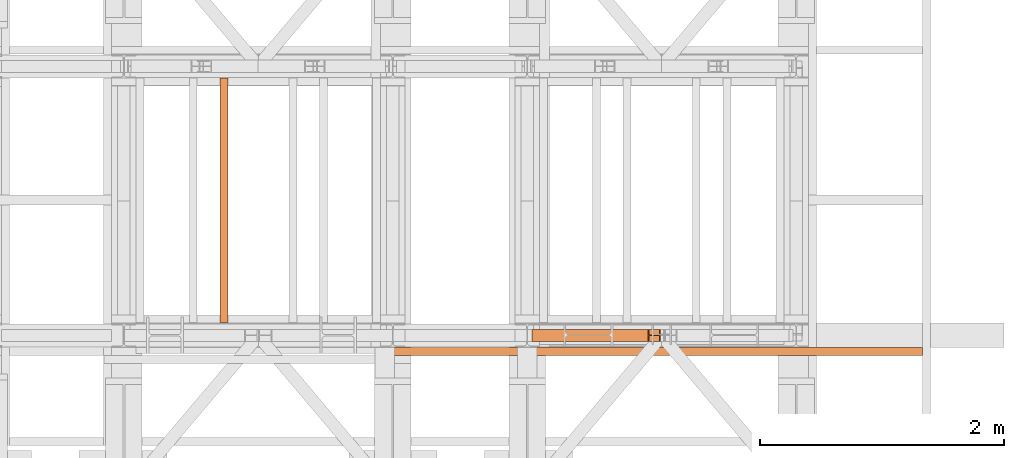
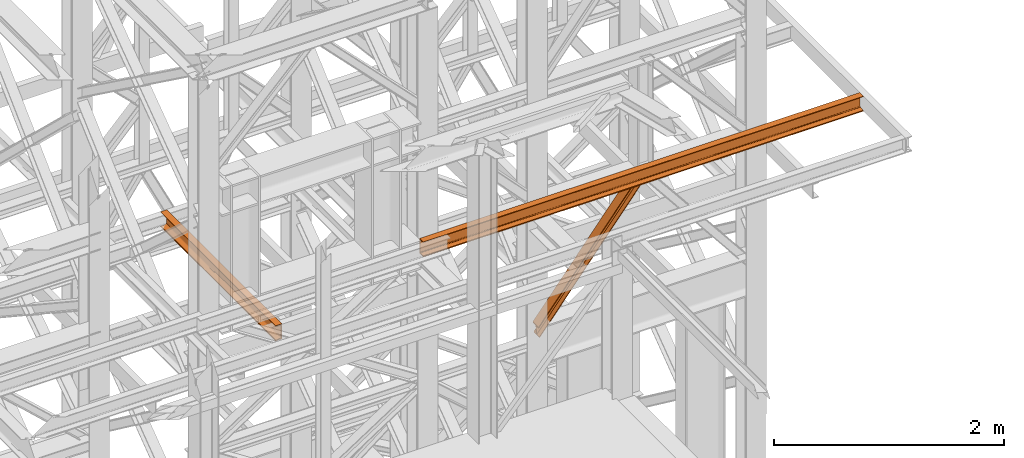
# One storey, part 155 of 208: 3 proxies.
"""IFC2X3 building model written with IfcOpenShell, lengths in millimetres."""

from ifc_helpers import new_model, entity, si_unit, converted_unit, frame, origin, origin_with_axes, place, context, subcontext, project, spatial, faceted_brep, element, save


model = new_model("IFC2X3")

# Units and contexts
model_context = context("Model", 3, precision=1e-05, world=origin())
plan_context = context("Plan", 3, precision=1e-05, world=origin())
body_context = subcontext(model_context, "Body", "Model", "MODEL_VIEW")
ifc_project = project(units=[si_unit("LENGTHUNIT", "METRE", prefix="MILLI"), converted_unit("PLANEANGLEUNIT", "DEGREE", entity("IfcPlaneAngleMeasure", 0.0174532925199433), si_unit("PLANEANGLEUNIT", "RADIAN"), dimensions=[0, 0, 0, 0, 0, 0, 0]), si_unit("AREAUNIT", "SQUARE_METRE"), si_unit("VOLUMEUNIT", "CUBIC_METRE")], contexts=[model_context, plan_context])

# Building, storey
building_placement = place(None, origin())
building = spatial("IfcBuilding", under=ifc_project, at=building_placement, CompositionType="COMPLEX")
storey_placement = place(building_placement, origin_with_axes())
storey = spatial("IfcBuildingStorey", under=building, at=storey_placement, Name="Geschoss", CompositionType="ELEMENT")

# Proxies
proxy_1_placement = place(storey_placement, frame((6630.378002934955, -16012.57439031789, 8339.352060260173), z_axis=(0.0, 0.0, 1.0), x_axis=(1.0, 0.0, 0.0)))
element("IfcBuildingElementProxy", 1, at=proxy_1_placement, inside=storey, context=body_context, shape_type="Brep", body=[
    faceted_brep([(1045.056958792547, 100.010000000002, 1299.647998433631), (10.21836007813363, 100.0100000000002, 9.64798844986035), (11.14639281250948, 100.0100000000002, 0.01000000000021828), (1053.725645164412, 100.010000000002, 1299.647998433631), (1053.725645164412, 100.010000000002, 1299.647998433631), (11.14639281250948, 100.0100000000002, 0.01000000000021828), (11.14639281250948, 0.01000000000021828, 0.01000000000021828), (1053.725645164412, 0.01000000000203727, 1299.647998433631), (1053.725645164412, 0.01000000000203727, 1299.647998433631), (11.14639281250948, 0.01000000000021828, 0.01000000000021828), (10.21836007813363, 0.01000000000021828, 9.64798844986035), (1045.056958792546, 0.01000000000203727, 1299.647998433631), (1045.056958792546, 0.01000000000203727, 1299.647998433631), (10.21836007813363, 0.01000000000021828, 9.64798844986035), (10.21836007813363, 47.51000000000022, 9.64798844986035), (1045.056958792546, 47.51000000000204, 1299.647998433631), (1045.056958792546, 47.51000000000204, 1299.647998433631), (10.21836007813363, 47.51000000000022, 9.64798844986035), (0.938032734376975, 47.51000000000022, 106.0278729484544), (958.3706237147262, 47.51000000000204, 1299.647998433631), (958.3706237147262, 47.51000000000204, 1299.647998433631), (0.938032734376975, 47.51000000000022, 106.0278729484544), (0.938032734375156, 0.01000000000021828, 106.0278729484544), (958.3706237147271, 0.01000000000203727, 1299.647998433631), (958.3706237147271, 0.01000000000203727, 1299.647998433631), (0.938032734375156, 0.01000000000021828, 106.0278729484544), (0.01000000000112777, 0.01000000000021828, 115.6658613983145), (949.7020481829277, 0.01000000000203727, 1299.647998433631), (949.7020481829277, 0.01000000000203727, 1299.647998433631), (0.01000000000112777, 0.01000000000021828, 115.6658613983145), (0.009999999999308784, 100.0100000000002, 115.6658613983145), (949.7020481829268, 100.010000000002, 1299.647998433631), (949.7020481829268, 100.010000000002, 1299.647998433631), (0.009999999999308784, 100.0100000000002, 115.6658613983145), (0.938032734375156, 100.0100000000002, 106.0278729484544), (958.3706237147253, 100.010000000002, 1299.647998433631), (958.3706237147253, 100.010000000002, 1299.647998433631), (0.938032734375156, 100.0100000000002, 106.0278729484544), (0.938032734375156, 52.51000000000022, 106.0278729484544), (958.3706237147271, 52.51000000000204, 1299.647998433631), (958.3706237147271, 52.51000000000204, 1299.647998433631), (0.938032734375156, 52.51000000000022, 106.0278729484544), (10.21836007813363, 52.51000000000022, 9.64798844986035), (1045.056958792546, 52.51000000000204, 1299.647998433631), (1045.056958792546, 52.51000000000204, 1299.647998433631), (10.21836007813363, 52.51000000000022, 9.64798844986035), (10.21836007813363, 100.0100000000002, 9.64798844986035), (1045.056958792547, 100.010000000002, 1299.647998433631), (10.21836007813363, 100.0100000000002, 9.64798844986035), (10.21836007813363, 52.51000000000022, 9.64798844986035), (0.938032734375156, 52.51000000000022, 106.0278729484544), (0.938032734375156, 100.0100000000002, 106.0278729484544), (0.009999999999308784, 100.0100000000002, 115.6658613983145), (0.01000000000112777, 0.01000000000021828, 115.6658613983145), (0.938032734375156, 0.01000000000021828, 106.0278729484544), (0.938032734376975, 47.51000000000022, 106.0278729484544), (10.21836007813363, 47.51000000000022, 9.64798844986035), (10.21836007813363, 0.01000000000021828, 9.64798844986035), (11.14639281250948, 0.01000000000021828, 0.01000000000021828), (11.14639281250948, 100.0100000000002, 0.01000000000021828), (1053.725645164412, 100.010000000002, 1299.647998433631), (1053.725645164412, 0.01000000000203727, 1299.647998433631), (1045.056958792546, 0.01000000000203727, 1299.647998433631), (1045.056958792546, 47.51000000000204, 1299.647998433631), (958.3706237147262, 47.51000000000204, 1299.647998433631), (958.3706237147271, 0.01000000000203727, 1299.647998433631), (949.7020481829277, 0.01000000000203727, 1299.647998433631), (949.7020481829268, 100.010000000002, 1299.647998433631), (958.3706237147253, 100.010000000002, 1299.647998433631), (958.3706237147271, 52.51000000000204, 1299.647998433631), (1045.056958792546, 52.51000000000204, 1299.647998433631), (1045.056958792547, 100.010000000002, 1299.647998433631)], [[[0, 1, 2, 3]], [[4, 5, 6, 7]], [[8, 9, 10, 11]], [[12, 13, 14, 15]], [[16, 17, 18, 19]], [[20, 21, 22, 23]], [[24, 25, 26, 27]], [[28, 29, 30, 31]], [[32, 33, 34, 35]], [[36, 37, 38, 39]], [[40, 41, 42, 43]], [[44, 45, 46, 47]], [[48, 49, 50, 51, 52, 53, 54, 55, 56, 57, 58, 59]], [[60, 61, 62, 63, 64, 65, 66, 67, 68, 69, 70, 71]]], orient=[[False], [False], [False], [False], [False], [False], [False], [False], [False], [False], [False], [False], [False], [False]]),
])
proxy_2_placement = place(storey_placement, frame((4078.254968528665, -15857.57439274273, 9109.989999999998), z_axis=(0.0, 0.0, 1.0), x_axis=(1.0, 0.0, 0.0)))
element("IfcBuildingElementProxy", 2, at=proxy_2_placement, inside=storey, context=body_context, shape_type="Brep", body=[
    faceted_brep([(65.01000000000022, 2000.009997019768, 160.0100000000002), (65.01000000000204, 0.01000000000021828, 160.0100000000002), (0.01000000000203727, 0.01000000000021828, 160.0100000000002), (0.01000000000021828, 2000.009997019768, 160.0100000000002), (0.01000000000021828, 2000.009997019768, 160.0100000000002), (0.01000000000203727, 0.01000000000021828, 160.0100000000002), (0.01000000000203727, 0.01000000000021828, 156.8875719297539), (0.01000000000021828, 2000.009997019768, 156.8875719297539), (0.01000000000021828, 2000.009997019768, 156.8875719297539), (0.01000000000203727, 0.01000000000021828, 156.8875719297539), (0.2527365771748009, 0.01000000000021828, 155.2717110918293), (0.2527365771729819, 2000.009997019768, 155.2717110918293), (0.2527365771729819, 2000.009997019768, 155.2717110918293), (0.2527365771748009, 0.01000000000021828, 155.2717110918293), (0.9594677141431021, 0.01000000000021828, 153.7984655565542), (0.959467714144921, 2000.009997019768, 153.7984655565542), (0.959467714144921, 2000.009997019768, 153.7984655565542), (0.9594677141431021, 0.01000000000021828, 153.7984655565542), (2.067848361533834, 0.01000000000021828, 152.5978732961266), (2.067848361532015, 2000.009997019768, 152.5978732961266), (2.067848361532015, 2000.009997019768, 152.5978732961266), (2.067848361533834, 0.01000000000021828, 152.5978732961266), (3.480043588519038, 0.01000000000021828, 151.7759086082897), (3.480043588517219, 2000.009997019768, 151.7759086082897), (3.480043588517219, 2000.009997019768, 151.7759086082897), (3.480043588519038, 0.01000000000021828, 151.7759086082897), (5.071401277447876, 0.01000000000021828, 151.4050878978051), (5.071401277446057, 2000.009997019768, 151.4050878978051), (5.071401277446057, 2000.009997019768, 151.4050878978051), (5.071401277447876, 0.01000000000021828, 151.4050878978051), (47.84732483397238, 0.01000000000021828, 147.9830140132835), (47.84732483397056, 2000.009997019768, 147.9830140132835), (47.84732483397056, 2000.009997019768, 147.9830140132835), (47.84732483397238, 0.01000000000021828, 147.9830140132835), (50.81159179199312, 0.01000000000021828, 147.318026761528), (50.8115917919913, 2000.009997019768, 147.318026761528), (50.8115917919913, 2000.009997019768, 147.318026761528), (50.81159179199312, 0.01000000000021828, 147.318026761528), (53.58138040071208, 0.01000000000021828, 145.7058782528511), (53.5813804007139, 2000.009997019768, 145.7058782528511), (53.5813804007139, 2000.009997019768, 145.7058782528511), (53.58138040071208, 0.01000000000021828, 145.7058782528511), (55.69737981845537, 0.01000000000021828, 143.4138384829421), (55.69737981845356, 2000.009997019768, 143.4138384829421), (55.69737981845356, 2000.009997019768, 143.4138384829421), (55.69737981845537, 0.01000000000021828, 143.4138384829421), (57.04659380721569, 0.01000000000021828, 140.6012788246917), (57.04659380721387, 2000.009997019768, 140.6012788246917), (57.04659380721387, 2000.009997019768, 140.6012788246917), (57.04659380721569, 0.01000000000021828, 140.6012788246917), (57.51000000000204, 0.01000000000021828, 137.5164535886543), (57.51000000000022, 2000.009997019768, 137.5164535886543), (57.51000000000022, 2000.009997019768, 137.5164535886543), (57.51000000000204, 0.01000000000021828, 137.5164535886543), (57.51000000000204, 0.01000000000021828, 22.503546411348), (57.51000000000022, 2000.009997019768, 22.503546411348), (57.51000000000022, 2000.009997019768, 22.503546411348), (57.51000000000204, 0.01000000000021828, 22.503546411348), (57.04659380721569, 0.01000000000021828, 19.41872117530875), (57.04659380721387, 2000.009997019768, 19.41872117530875), (57.04659380721387, 2000.009997019768, 19.41872117530875), (57.04659380721569, 0.01000000000021828, 19.41872117530875), (55.69737981845537, 0.01000000000021828, 16.60616151705835), (55.69737981845356, 2000.009997019768, 16.60616151705835), (55.69737981845356, 2000.009997019768, 16.60616151705835), (55.69737981845537, 0.01000000000021828, 16.60616151705835), (53.58138040071208, 0.01000000000021828, 14.31412174714933), (53.5813804007139, 2000.009997019768, 14.31412174714933), (53.5813804007139, 2000.009997019768, 14.31412174714933), (53.58138040071208, 0.01000000000021828, 14.31412174714933), (50.88537133101636, 0.01000000000021828, 12.74491643400688), (50.88537133101818, 2000.009997019768, 12.74491643400688), (50.88537133101818, 2000.009997019768, 12.74491643400688), (50.88537133101636, 0.01000000000021828, 12.74491643400688), (47.84732483397238, 0.01000000000021828, 12.03698598671872), (47.84732483397056, 2000.009997019768, 12.03698598671872), (47.84732483397056, 2000.009997019768, 12.03698598671872), (47.84732483397238, 0.01000000000021828, 12.03698598671872), (5.071401277447876, 0.01000000000021828, 8.614912102195376), (5.071401277446057, 2000.009997019768, 8.614912102195376), (5.071401277446057, 2000.009997019768, 8.614912102195376), (5.071401277447876, 0.01000000000021828, 8.614912102195376), (3.480043588519038, 0.01000000000021828, 8.244091391710754), (3.480043588517219, 2000.009997019768, 8.244091391710754), (3.480043588517219, 2000.009997019768, 8.244091391710754), (3.480043588519038, 0.01000000000021828, 8.244091391710754), (2.067848361533834, 0.01000000000021828, 7.422126703873801), (2.067848361532015, 2000.009997019768, 7.422126703873801), (2.067848361532015, 2000.009997019768, 7.422126703873801), (2.067848361533834, 0.01000000000021828, 7.422126703873801), (0.9594677141431021, 0.01000000000021828, 6.221534443446217), (0.959467714144921, 2000.009997019768, 6.221534443446217), (0.959467714144921, 2000.009997019768, 6.221534443446217), (0.9594677141431021, 0.01000000000021828, 6.221534443446217), (0.2527365771748009, 0.01000000000021828, 4.748288908172981), (0.2527365771729819, 2000.009997019768, 4.748288908172981), (0.2527365771729819, 2000.009997019768, 4.748288908172981), (0.2527365771748009, 0.01000000000021828, 4.748288908172981), (0.01000000000203727, 0.01000000000021828, 0.01000000000021828), (0.01000000000021828, 2000.009997019768, 0.01000000000021828), (0.01000000000021828, 2000.009997019768, 0.01000000000021828), (0.01000000000203727, 0.01000000000021828, 0.01000000000021828), (65.01000000000204, 0.01000000000021828, 0.01000000000021828), (65.01000000000022, 2000.009997019768, 0.01000000000021828), (65.01000000000022, 2000.009997019768, 0.01000000000021828), (65.01000000000204, 0.01000000000021828, 0.01000000000021828), (65.01000000000204, 0.01000000000021828, 160.0100000000002), (65.01000000000022, 2000.009997019768, 160.0100000000002), (65.01000000000022, 2000.009997019768, 160.0100000000002), (0.01000000000021828, 2000.009997019768, 160.0100000000002), (0.01000000000021828, 2000.009997019768, 156.8875719297539), (0.2527365771729819, 2000.009997019768, 155.2717110918293), (0.959467714144921, 2000.009997019768, 153.7984655565542), (2.067848361532015, 2000.009997019768, 152.5978732961266), (3.480043588517219, 2000.009997019768, 151.7759086082897), (5.071401277446057, 2000.009997019768, 151.4050878978051), (47.84732483397056, 2000.009997019768, 147.9830140132835), (50.8115917919913, 2000.009997019768, 147.318026761528), (53.5813804007139, 2000.009997019768, 145.7058782528511), (55.69737981845356, 2000.009997019768, 143.4138384829421), (57.04659380721387, 2000.009997019768, 140.6012788246917), (57.51000000000022, 2000.009997019768, 137.5164535886543), (57.51000000000022, 2000.009997019768, 22.503546411348), (57.04659380721387, 2000.009997019768, 19.41872117530875), (55.69737981845356, 2000.009997019768, 16.60616151705835), (53.5813804007139, 2000.009997019768, 14.31412174714933), (50.88537133101818, 2000.009997019768, 12.74491643400688), (47.84732483397056, 2000.009997019768, 12.03698598671872), (5.071401277446057, 2000.009997019768, 8.614912102195376), (3.480043588517219, 2000.009997019768, 8.244091391710754), (2.067848361532015, 2000.009997019768, 7.422126703873801), (0.959467714144921, 2000.009997019768, 6.221534443446217), (0.2527365771729819, 2000.009997019768, 4.748288908172981), (0.01000000000021828, 2000.009997019768, 0.01000000000021828), (65.01000000000022, 2000.009997019768, 0.01000000000021828), (65.01000000000204, 0.01000000000021828, 160.0100000000002), (65.01000000000204, 0.01000000000021828, 0.01000000000021828), (0.01000000000203727, 0.01000000000021828, 0.01000000000021828), (0.2527365771748009, 0.01000000000021828, 4.748288908172981), (0.9594677141431021, 0.01000000000021828, 6.221534443446217), (2.067848361533834, 0.01000000000021828, 7.422126703873801), (3.480043588519038, 0.01000000000021828, 8.244091391710754), (5.071401277447876, 0.01000000000021828, 8.614912102195376), (47.84732483397238, 0.01000000000021828, 12.03698598671872), (50.88537133101636, 0.01000000000021828, 12.74491643400688), (53.58138040071208, 0.01000000000021828, 14.31412174714933), (55.69737981845537, 0.01000000000021828, 16.60616151705835), (57.04659380721569, 0.01000000000021828, 19.41872117530875), (57.51000000000204, 0.01000000000021828, 22.503546411348), (57.51000000000204, 0.01000000000021828, 137.5164535886543), (57.04659380721569, 0.01000000000021828, 140.6012788246917), (55.69737981845537, 0.01000000000021828, 143.4138384829421), (53.58138040071208, 0.01000000000021828, 145.7058782528511), (50.81159179199312, 0.01000000000021828, 147.318026761528), (47.84732483397238, 0.01000000000021828, 147.9830140132835), (5.071401277447876, 0.01000000000021828, 151.4050878978051), (3.480043588519038, 0.01000000000021828, 151.7759086082897), (2.067848361533834, 0.01000000000021828, 152.5978732961266), (0.9594677141431021, 0.01000000000021828, 153.7984655565542), (0.2527365771748009, 0.01000000000021828, 155.2717110918293), (0.01000000000203727, 0.01000000000021828, 156.8875719297539), (0.01000000000203727, 0.01000000000021828, 160.0100000000002)], [[[0, 1, 2, 3]], [[4, 5, 6, 7]], [[8, 9, 10, 11]], [[12, 13, 14, 15]], [[16, 17, 18, 19]], [[20, 21, 22, 23]], [[24, 25, 26, 27]], [[28, 29, 30, 31]], [[32, 33, 34, 35]], [[36, 37, 38, 39]], [[40, 41, 42, 43]], [[44, 45, 46, 47]], [[48, 49, 50, 51]], [[52, 53, 54, 55]], [[56, 57, 58, 59]], [[60, 61, 62, 63]], [[64, 65, 66, 67]], [[68, 69, 70, 71]], [[72, 73, 74, 75]], [[76, 77, 78, 79]], [[80, 81, 82, 83]], [[84, 85, 86, 87]], [[88, 89, 90, 91]], [[92, 93, 94, 95]], [[96, 97, 98, 99]], [[100, 101, 102, 103]], [[104, 105, 106, 107]], [[108, 109, 110, 111, 112, 113, 114, 115, 116, 117, 118, 119, 120, 121, 122, 123, 124, 125, 126, 127, 128, 129, 130, 131, 132, 133, 134]], [[135, 136, 137, 138, 139, 140, 141, 142, 143, 144, 145, 146, 147, 148, 149, 150, 151, 152, 153, 154, 155, 156, 157, 158, 159, 160, 161]]], orient=[[False], [False], [False], [False], [False], [False], [False], [False], [False], [False], [False], [False], [False], [False], [False], [False], [False], [False], [False], [False], [False], [False], [False], [False], [False], [False], [False], [False], [False]]),
])
proxy_3_placement = place(storey_placement, frame((5408.431544741356, -16127.574391808, 9699.99), z_axis=(0.0, 0.0, 1.0), x_axis=(1.0, 0.0, 0.0)))
element("IfcBuildingElementProxy", 3, at=proxy_3_placement, inside=storey, context=body_context, shape_type="Brep", body=[
    faceted_brep([(0.01000000000021828, 0.01000000000021828, 0.01000000000021828), (0.01000000000021828, 0.01000000000021828, 3.132428070246533), (4419.590688700255, 0.01000000000021828, 3.132428070246533), (4419.590688700255, 0.01000000000021828, 0.01000000000021828), (0.01000000000021828, 0.01000000000021828, 3.132428070246533), (0.01000000000021828, 0.2527365771729819, 4.748288908171162), (4419.590688700255, 0.2527365771729819, 4.748288908171162), (4419.590688700255, 0.01000000000021828, 3.132428070246533), (0.01000000000021828, 0.2527365771729819, 4.748288908171162), (0.01000000000021828, 0.9594677141431021, 6.221534443444398), (4419.590688700255, 0.9594677141431021, 6.221534443444398), (4419.590688700255, 0.2527365771729819, 4.748288908171162), (0.01000000000021828, 0.9594677141431021, 6.221534443444398), (0.01000000000021828, 2.067848361530196, 7.422126703873801), (4419.590688700255, 2.067848361530196, 7.422126703873801), (4419.590688700255, 0.9594677141431021, 6.221534443444398), (0.01000000000021828, 2.067848361530196, 7.422126703873801), (0.01000000000021828, 3.4800435885154, 8.244091391710754), (4419.590688700255, 3.4800435885154, 8.244091391710754), (4419.590688700255, 2.067848361530196, 7.422126703873801), (0.01000000000021828, 3.4800435885154, 8.244091391710754), (0.01000000000021828, 5.071401277444238, 8.614912102195376), (4419.590688700255, 5.071401277444238, 8.614912102195376), (4419.590688700255, 3.4800435885154, 8.244091391710754), (0.01000000000021828, 5.071401277444238, 8.614912102195376), (0.01000000000021828, 47.84732483397056, 12.0369859867169), (4419.590688700255, 47.84732483397056, 12.0369859867169), (4419.590688700255, 5.071401277444238, 8.614912102195376), (0.01000000000021828, 47.84732483397056, 12.0369859867169), (0.01000000000021828, 50.88537133101636, 12.74491643400506), (4419.590688700255, 50.88537133101636, 12.74491643400506), (4419.590688700255, 47.84732483397056, 12.0369859867169), (0.01000000000021828, 50.88537133101636, 12.74491643400506), (0.01000000000021828, 53.58138040071208, 14.31412174714933), (4419.590688700255, 53.5813804007139, 14.31412174714933), (4419.590688700255, 50.88537133101636, 12.74491643400506), (0.01000000000021828, 53.58138040071208, 14.31412174714933), (0.01000000000021828, 55.69737981845174, 16.60616151705835), (4419.590688700255, 55.69737981845356, 16.60616151705835), (4419.590688700255, 53.5813804007139, 14.31412174714933), (0.01000000000021828, 55.69737981845174, 16.60616151705835), (0.01000000000021828, 57.04659380721387, 19.41872117530875), (4419.590688700255, 57.04659380721387, 19.41872117530875), (4419.590688700255, 55.69737981845356, 16.60616151705835), (0.01000000000021828, 57.04659380721387, 19.41872117530875), (0.01000000000021828, 57.51000000000022, 22.50354641134618), (4419.590688700255, 57.51000000000022, 22.50354641134618), (4419.590688700255, 57.04659380721387, 19.41872117530875), (0.01000000000021828, 57.51000000000022, 22.50354641134618), (0.01000000000021828, 57.51000000000022, 137.5164535886524), (4419.590688700255, 57.51000000000022, 137.5164535886524), (4419.590688700255, 57.51000000000022, 22.50354641134618), (0.01000000000021828, 57.51000000000022, 137.5164535886524), (0.01000000000021828, 57.04659380721387, 140.6012788246917), (4419.590688700255, 57.04659380721387, 140.6012788246917), (4419.590688700255, 57.51000000000022, 137.5164535886524), (0.01000000000021828, 57.04659380721387, 140.6012788246917), (0.01000000000021828, 55.69737981845174, 143.4138384829403), (4419.590688700255, 55.69737981845356, 143.4138384829403), (4419.590688700255, 57.04659380721387, 140.6012788246917), (0.01000000000021828, 55.69737981845174, 143.4138384829403), (0.01000000000021828, 53.58138040071208, 145.7058782528493), (4419.590688700255, 53.5813804007139, 145.7058782528493), (4419.590688700255, 55.69737981845356, 143.4138384829403), (0.01000000000021828, 53.58138040071208, 145.7058782528493), (0.01000000000021828, 50.88537133101636, 147.2750835659936), (4419.590688700255, 50.88537133101636, 147.2750835659936), (4419.590688700255, 53.5813804007139, 145.7058782528493), (0.01000000000021828, 50.88537133101636, 147.2750835659936), (0.01000000000021828, 47.84732483397056, 147.9830140132817), (4419.590688700255, 47.84732483397056, 147.9830140132817), (4419.590688700255, 50.88537133101636, 147.2750835659936), (0.01000000000021828, 47.84732483397056, 147.9830140132817), (0.01000000000021828, 5.071401277444238, 151.4050878978032), (4419.590688700255, 5.071401277444238, 151.4050878978032), (4419.590688700255, 47.84732483397056, 147.9830140132817), (0.01000000000021828, 5.071401277444238, 151.4050878978032), (0.01000000000021828, 3.4800435885154, 151.7759086082879), (4419.590688700255, 3.4800435885154, 151.7759086082879), (4419.590688700255, 5.071401277444238, 151.4050878978032), (0.01000000000021828, 3.4800435885154, 151.7759086082879), (0.01000000000021828, 2.067848361530196, 152.5978732961248), (4419.590688700255, 2.067848361530196, 152.5978732961248), (4419.590688700255, 3.4800435885154, 151.7759086082879), (0.01000000000021828, 2.067848361530196, 152.5978732961248), (0.01000000000021828, 0.9594677141431021, 153.7984655565542), (4419.590688700255, 0.9594677141431021, 153.7984655565542), (4419.590688700255, 2.067848361530196, 152.5978732961248), (0.01000000000021828, 0.9594677141431021, 153.7984655565542), (0.01000000000021828, 0.2527365771729819, 155.2717110918275), (4419.590688700255, 0.2527365771729819, 155.2717110918275), (4419.590688700255, 0.9594677141431021, 153.7984655565542), (0.01000000000021828, 0.2527365771729819, 155.2717110918275), (0.01000000000021828, 0.01000000000021828, 156.8875719297521), (4419.590688700255, 0.01000000000021828, 156.8875719297521), (4419.590688700255, 0.2527365771729819, 155.2717110918275), (0.01000000000021828, 0.01000000000021828, 156.8875719297521), (0.01000000000021828, 0.01000000000021828, 160.0100000000002), (4419.590688700255, 0.01000000000021828, 160.0100000000002), (4419.590688700255, 0.01000000000021828, 156.8875719297521), (0.01000000000021828, 0.01000000000021828, 160.0100000000002), (0.01000000000021828, 65.01000000000022, 160.0100000000002), (4419.590688700255, 65.01000000000022, 160.0100000000002), (4419.590688700255, 0.01000000000021828, 160.0100000000002), (0.01000000000021828, 65.01000000000022, 160.0100000000002), (0.01000000000021828, 65.01000000000022, 0.01000000000021828), (4419.590688700255, 65.01000000000022, 0.01000000000021828), (4419.590688700255, 65.01000000000022, 160.0100000000002), (0.01000000000021828, 65.01000000000022, 0.01000000000021828), (0.01000000000021828, 0.01000000000021828, 0.01000000000021828), (4419.590688700255, 0.01000000000021828, 0.01000000000021828), (4419.590688700255, 65.01000000000022, 0.01000000000021828), (0.01000000000021828, 0.01000000000021828, 0.01000000000021828), (0.01000000000021828, 65.01000000000022, 0.01000000000021828), (0.01000000000021828, 65.01000000000022, 160.0100000000002), (0.01000000000021828, 0.01000000000021828, 160.0100000000002), (0.01000000000021828, 0.01000000000021828, 156.8875719297521), (0.01000000000021828, 0.2527365771729819, 155.2717110918275), (0.01000000000021828, 0.9594677141431021, 153.7984655565542), (0.01000000000021828, 2.067848361530196, 152.5978732961248), (0.01000000000021828, 3.4800435885154, 151.7759086082879), (0.01000000000021828, 5.071401277444238, 151.4050878978032), (0.01000000000021828, 47.84732483397056, 147.9830140132817), (0.01000000000021828, 50.88537133101636, 147.2750835659936), (0.01000000000021828, 53.58138040071208, 145.7058782528493), (0.01000000000021828, 55.69737981845174, 143.4138384829403), (0.01000000000021828, 57.04659380721387, 140.6012788246917), (0.01000000000021828, 57.51000000000022, 137.5164535886524), (0.01000000000021828, 57.51000000000022, 22.50354641134618), (0.01000000000021828, 57.04659380721387, 19.41872117530875), (0.01000000000021828, 55.69737981845174, 16.60616151705835), (0.01000000000021828, 53.58138040071208, 14.31412174714933), (0.01000000000021828, 50.88537133101636, 12.74491643400506), (0.01000000000021828, 47.84732483397056, 12.0369859867169), (0.01000000000021828, 5.071401277444238, 8.614912102195376), (0.01000000000021828, 3.4800435885154, 8.244091391710754), (0.01000000000021828, 2.067848361530196, 7.422126703873801), (0.01000000000021828, 0.9594677141431021, 6.221534443444398), (0.01000000000021828, 0.2527365771729819, 4.748288908171162), (0.01000000000021828, 0.01000000000021828, 3.132428070246533), (4419.590688700255, 0.01000000000021828, 0.01000000000021828), (4419.590688700255, 0.01000000000021828, 3.132428070246533), (4419.590688700255, 0.2527365771729819, 4.748288908171162), (4419.590688700255, 0.9594677141431021, 6.221534443444398), (4419.590688700255, 2.067848361530196, 7.422126703873801), (4419.590688700255, 3.4800435885154, 8.244091391710754), (4419.590688700255, 5.071401277444238, 8.614912102195376), (4419.590688700255, 47.84732483397056, 12.0369859867169), (4419.590688700255, 50.88537133101636, 12.74491643400506), (4419.590688700255, 53.5813804007139, 14.31412174714933), (4419.590688700255, 55.69737981845356, 16.60616151705835), (4419.590688700255, 57.04659380721387, 19.41872117530875), (4419.590688700255, 57.51000000000022, 22.50354641134618), (4419.590688700255, 57.51000000000022, 137.5164535886524), (4419.590688700255, 57.04659380721387, 140.6012788246917), (4419.590688700255, 55.69737981845356, 143.4138384829403), (4419.590688700255, 53.5813804007139, 145.7058782528493), (4419.590688700255, 50.88537133101636, 147.2750835659936), (4419.590688700255, 47.84732483397056, 147.9830140132817), (4419.590688700255, 5.071401277444238, 151.4050878978032), (4419.590688700255, 3.4800435885154, 151.7759086082879), (4419.590688700255, 2.067848361530196, 152.5978732961248), (4419.590688700255, 0.9594677141431021, 153.7984655565542), (4419.590688700255, 0.2527365771729819, 155.2717110918275), (4419.590688700255, 0.01000000000021828, 156.8875719297521), (4419.590688700255, 0.01000000000021828, 160.0100000000002), (4419.590688700255, 65.01000000000022, 160.0100000000002), (4419.590688700255, 65.01000000000022, 0.01000000000021828)], [[[0, 1, 2, 3]], [[4, 5, 6, 7]], [[8, 9, 10, 11]], [[12, 13, 14, 15]], [[16, 17, 18, 19]], [[20, 21, 22, 23]], [[24, 25, 26, 27]], [[28, 29, 30, 31]], [[32, 33, 34, 35]], [[36, 37, 38, 39]], [[40, 41, 42, 43]], [[44, 45, 46, 47]], [[48, 49, 50, 51]], [[52, 53, 54, 55]], [[56, 57, 58, 59]], [[60, 61, 62, 63]], [[64, 65, 66, 67]], [[68, 69, 70, 71]], [[72, 73, 74, 75]], [[76, 77, 78, 79]], [[80, 81, 82, 83]], [[84, 85, 86, 87]], [[88, 89, 90, 91]], [[92, 93, 94, 95]], [[96, 97, 98, 99]], [[100, 101, 102, 103]], [[104, 105, 106, 107]], [[108, 109, 110, 111]], [[112, 113, 114, 115, 116, 117, 118, 119, 120, 121, 122, 123, 124, 125, 126, 127, 128, 129, 130, 131, 132, 133, 134, 135, 136, 137, 138, 139]], [[140, 141, 142, 143, 144, 145, 146, 147, 148, 149, 150, 151, 152, 153, 154, 155, 156, 157, 158, 159, 160, 161, 162, 163, 164, 165, 166, 167]]], orient=[[False], [False], [False], [False], [False], [False], [False], [False], [False], [False], [False], [False], [False], [False], [False], [False], [False], [False], [False], [False], [False], [False], [False], [False], [False], [False], [False], [False], [False], [False]]),
])

save(model, "model.ifc")
